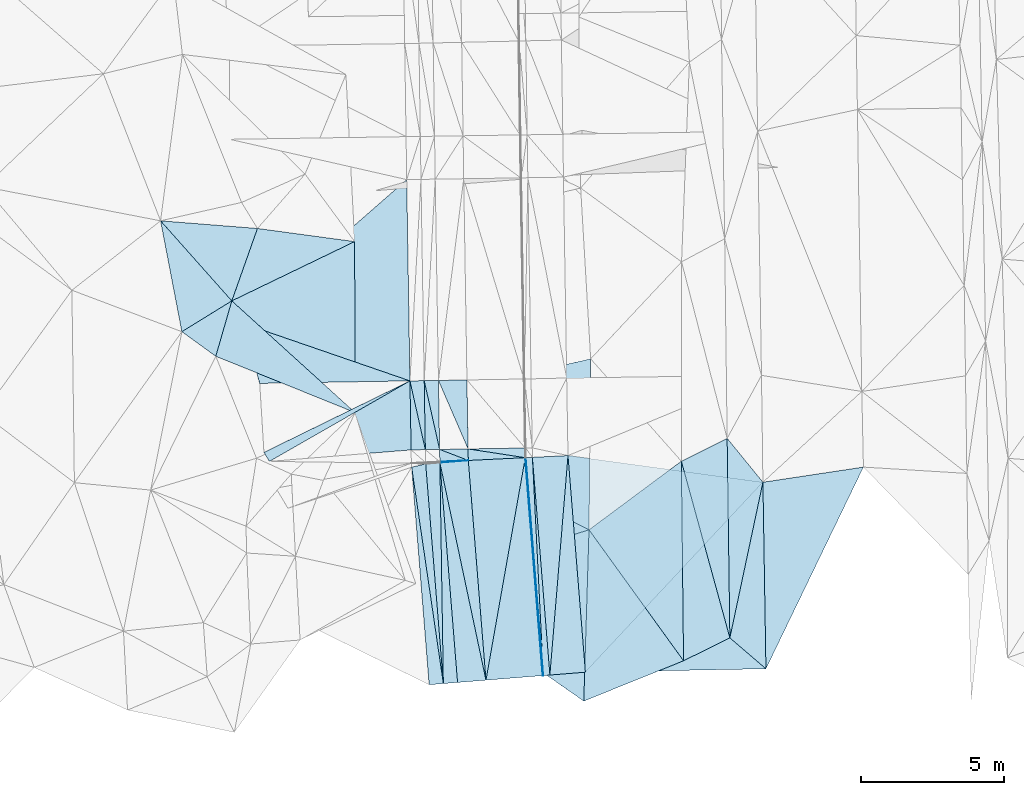
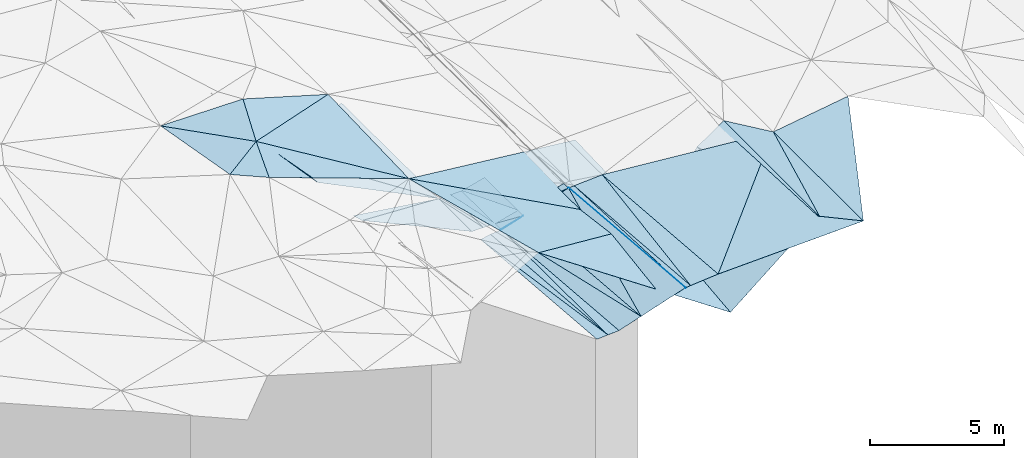
# One storey, part 4 of 275: 46 plates.
"""IFC2X3 building model written with IfcOpenShell, lengths in millimetres."""

from ifc_helpers import new_model, si_unit, frame, origin_with_axes, place, context, subcontext, project, spatial, polyline, outline, extrude, material, type_object, element, save


model = new_model("IFC2X3")

# Units and contexts
model_context = context("Model", 3, precision=1e-05, world=origin_with_axes())
body_context = subcontext(model_context, "Body", "Model", "MODEL_VIEW")
ifc_project = project(units=[si_unit("LENGTHUNIT", "METRE", prefix="MILLI"), si_unit("AREAUNIT", "SQUARE_METRE"), si_unit("VOLUMEUNIT", "CUBIC_METRE"), si_unit("MASSUNIT", "GRAM", prefix="KILO"), si_unit("TIMEUNIT", "SECOND"), si_unit("PLANEANGLEUNIT", "RADIAN"), si_unit("SOLIDANGLEUNIT", "STERADIAN"), si_unit("THERMODYNAMICTEMPERATUREUNIT", "DEGREE_CELSIUS"), si_unit("LUMINOUSINTENSITYUNIT", "LUMEN")], contexts=[model_context])

# Site, building, storey
site_placement = place(None, origin_with_axes())
site = spatial("IfcSite", under=ifc_project, at=site_placement, CompositionType="ELEMENT")
building_placement = place(site_placement, origin_with_axes())
building = spatial("IfcBuilding", under=site, at=building_placement, Name="Undefined", CompositionType="ELEMENT")
storey_placement = place(building_placement, origin_with_axes())
storey = spatial("IfcBuildingStorey", under=building, at=storey_placement, Name="Undefined", CompositionType="ELEMENT", Elevation=0.0)

# Plates
ifc_material = material()
plate_type_1 = type_object("IfcPlateType", PredefinedType="NOTDEFINED")
plate_1_placement = place(storey_placement, frame((-93903.9213803638, -27441.9689943814, 40420.7261829203), z_axis=(0.0194266666543734, 0.019288035695797, -0.999625217920045), x_axis=(0.082182286944694, 0.996399757859899, 0.0208229260497896)))
element("IfcPlate", 1, at=plate_1_placement, inside=storey, type_object=plate_type_1, material=ifc_material, Name="00_PR", context=body_context, shape_type="SweptSolid", body=[
    extrude(outline(polyline([(0.0, 0.0), (7727.4921875, -6.94126356393099e-09), (202.744781494141, 1233.72521972656), (0.0, 0.0)])), frame((-8.85201319254618e-08, 2.18876761149539e-07, -0.5000001331573), z_axis=(0.0, 0.0, 1.0), x_axis=(1.0, 0.0, 0.0)), (0.0, 0.0, 1.0), 1.0),
])
plate_type_2 = type_object("IfcPlateType", PredefinedType="NOTDEFINED")
plate_2_placement = place(storey_placement, frame((-94747.8302942082, -19814.3007240137, 40544.2796965373), z_axis=(0.0483613881429237, 0.0215259640727979, -0.998597921591882), x_axis=(0.0801182170397054, -0.996629915784215, -0.0176034730188981)))
element("IfcPlate", 2, at=plate_2_placement, inside=storey, type_object=plate_type_2, material=ifc_material, Name="00_PR", context=body_context, shape_type="SweptSolid", body=[
    extrude(outline(polyline([(0.0, 0.0), (7671.9521484375, 7.34871719032526e-09), (7671.9697265625, 20.0246315002441), (0.0, 0.0)])), frame((-8.85201319254618e-08, 2.18876761149539e-07, -0.5000001331573), z_axis=(0.0, 0.0, 1.0), x_axis=(1.0, 0.0, 0.0)), (0.0, 0.0, 1.0), 1.0),
])
plate_3_placement = place(storey_placement, frame((-94767.816333404, -19815.2740898309, 40543.288699556), z_axis=(0.0484659400334962, 0.0215340020153302, -0.998592679431345), x_axis=(0.997593448085874, 0.0485850940500555, 0.0494651490676421)))
element("IfcPlate", 3, at=plate_3_placement, inside=storey, type_object=plate_type_2, material=ifc_material, Name="00_PR", context=body_context, shape_type="SweptSolid", body=[
    extrude(outline(polyline([(0.0, 0.0), (20.0343074798584, -1.25510268844664e-10), (235.036758422852, 7668.982421875), (0.0, 0.0)])), frame((-8.85201319254618e-08, 2.18876761149539e-07, -0.5000001331573), z_axis=(0.0, 0.0, 1.0), x_axis=(1.0, 0.0, 0.0)), (0.0, 0.0, 1.0), 1.0),
])
plate_type_3 = type_object("IfcPlateType", PredefinedType="NOTDEFINED")
plate_4_placement = place(storey_placement, frame((-98753.8710590969, -20149.5700390411, 39792.5850713976), z_axis=(-0.00138706794295078, 0.017489506923386, -0.999846084750097), x_axis=(0.972984894181079, 0.230853132107295, 0.00268832507080703)))
element("IfcPlate", 4, at=plate_4_placement, inside=storey, type_object=plate_type_3, material=ifc_material, Name="00_PR", context=body_context, shape_type="SweptSolid", body=[
    extrude(outline(polyline([(0.0, 0.0), (505.891265869141, -1.30967237055302e-10), (-671.246215820313, 7645.65234375), (0.0, 0.0)])), frame((-8.85201319254618e-08, 2.18876761149539e-07, -0.5000001331573), z_axis=(0.0, 0.0, 1.0), x_axis=(1.0, 0.0, 0.0)), (0.0, 0.0, 1.0), 1.0),
])
plate_5_placement = place(storey_placement, frame((-97641.8728961927, -27742.4601534167, 39658.2260711417), z_axis=(-0.00140573286272345, 0.0174867737519264, -0.999846106487827), x_axis=(-0.996784432987784, -0.0801298580631551, -6.42321656705496e-11)))
element("IfcPlate", 5, at=plate_5_placement, inside=storey, type_object=plate_type_3, material=ifc_material, Name="00_PR", context=body_context, shape_type="SweptSolid", body=[
    extrude(outline(polyline([(0.0, 0.0), (499.999908447266, 1.81171344593167e-09), (500.005249023438, 7658.75732421875), (0.0, 0.0)])), frame((-8.85201319254618e-08, 2.18876761149539e-07, -0.5000001331573), z_axis=(0.0, 0.0, 1.0), x_axis=(1.0, 0.0, 0.0)), (0.0, 0.0, 1.0), 1.0),
])
plate_6_placement = place(storey_placement, frame((-98813.807881821, -17121.3449532891, 39843.868083752), z_axis=(-0.000313744370761918, 0.018873461419881, -0.999821831137179), x_axis=(0.999861856982811, 0.016621280061555, 5.8833362722147e-11)))
element("IfcPlate", 6, at=plate_6_placement, inside=storey, type_object=plate_type_3, material=ifc_material, Name="00_PR", context=body_context, shape_type="SweptSolid", body=[
    extrude(outline(polyline([(0.0, 0.0), (500.000274658203, -1.08957465272397e-09), (500.485961914063, 2422.11450195313), (0.0, 0.0)])), frame((-8.85201319254618e-08, 2.18876761149539e-07, -0.5000001331573), z_axis=(0.0, 0.0, 1.0), x_axis=(1.0, 0.0, 0.0)), (0.0, 0.0, 1.0), 1.0),
])
plate_7_placement = place(storey_placement, frame((-98273.139581764, -19534.3746465344, 39798.1480836798), z_axis=(-0.000321296187020533, 0.0188717701491486, -0.999821860663287), x_axis=(-0.999855102254091, -0.0170227640664222, -5.88479248151984e-11)))
element("IfcPlate", 7, at=plate_7_placement, inside=storey, type_object=plate_type_3, material=ifc_material, Name="00_PR", context=body_context, shape_type="SweptSolid", body=[
    extrude(outline(polyline([(0.0, 0.0), (500.000183105469, -1.82262738235295e-09), (499.513519287109, 2422.31518554688), (0.0, 0.0)])), frame((-8.85201319254618e-08, 2.18876761149539e-07, -0.5000001331573), z_axis=(0.0, 0.0, 1.0), x_axis=(1.0, 0.0, 0.0)), (0.0, 0.0, 1.0), 1.0),
])
plate_8_placement = place(storey_placement, frame((-97763.2543987342, -19992.7185375862, 39793.94507152), z_axis=(-0.00140583164995119, 0.017487998141806, -0.999846084934258), x_axis=(0.0156583300668846, -0.999724107342226, -0.0175078810341733)))
element("IfcPlate", 8, at=plate_8_placement, inside=storey, type_object=plate_type_3, material=ifc_material, Name="00_PR", context=body_context, shape_type="SweptSolid", body=[
    extrude(outline(polyline([(0.0, 0.0), (7751.88037109375, 6.53380993753672e-09), (32.2498779296875, 498.958770751953), (0.0, 0.0)])), frame((-8.85201319254618e-08, 2.18876761149539e-07, -0.5000001331573), z_axis=(0.0, 0.0, 1.0), x_axis=(1.0, 0.0, 0.0)), (0.0, 0.0, 1.0), 1.0),
])
plate_9_placement = place(storey_placement, frame((-97641.8728961927, -27742.4601534167, 39658.2260711417), z_axis=(-0.00140583164995119, 0.017487998141806, -0.999846084934258), x_axis=(-0.0156583300654786, 0.999724107342249, 0.0175078810340888)))
element("IfcPlate", 9, at=plate_9_placement, inside=storey, type_object=plate_type_3, material=ifc_material, Name="00_PR", context=body_context, shape_type="SweptSolid", body=[
    extrude(outline(polyline([(0.0, 0.0), (7751.88037109375, 6.53380993753672e-09), (32.2511901855469, 498.959289550781), (0.0, 0.0)])), frame((-8.85201319254618e-08, 2.18876761149539e-07, -0.5000001331573), z_axis=(0.0, 0.0, 1.0), x_axis=(1.0, 0.0, 0.0)), (0.0, 0.0, 1.0), 1.0),
])
plate_10_placement = place(storey_placement, frame((-98313.8766980168, -17113.0343081241, 39843.8680841482), z_axis=(-0.000313755649375687, 0.0188750254590119, -0.999821801608324), x_axis=(0.999861856982811, 0.016621280061555, 5.8833362722147e-11)))
element("IfcPlate", 10, at=plate_10_placement, inside=storey, type_object=plate_type_3, material=ifc_material, Name="00_PR", context=body_context, shape_type="SweptSolid", body=[
    extrude(outline(polyline([(0.0, 0.0), (499.999328613281, 2.29920260608196e-09), (500.48681640625, 2421.91381835938), (0.0, 0.0)])), frame((-8.85201319254618e-08, 2.18876761149539e-07, -0.5000001331573), z_axis=(0.0, 0.0, 1.0), x_axis=(1.0, 0.0, 0.0)), (0.0, 0.0, 1.0), 1.0),
])
plate_11_placement = place(storey_placement, frame((-97773.2127767871, -19525.8636657741, 39798.1480842726), z_axis=(-0.000321308115323835, 0.0188733341866267, -0.999821831136816), x_axis=(-0.999855102254091, -0.0170227640664222, -5.88479248151984e-11)))
element("IfcPlate", 11, at=plate_11_placement, inside=storey, type_object=plate_type_3, material=ifc_material, Name="00_PR", context=body_context, shape_type="SweptSolid", body=[
    extrude(outline(polyline([(0.0, 0.0), (499.999237060547, -2.32103047892451e-09), (499.514434814453, 2422.11450195313), (0.0, 0.0)])), frame((-8.85201319254618e-08, 2.18876761149539e-07, -0.5000001331573), z_axis=(0.0, 0.0, 1.0), x_axis=(1.0, 0.0, 0.0)), (0.0, 0.0, 1.0), 1.0),
])
plate_type_4 = type_object("IfcPlateType", PredefinedType="NOTDEFINED")
plate_12_placement = place(storey_placement, frame((-94517.9869639857, -19803.1105005085, 40555.6756991501), z_axis=(0.0484634257975121, 0.0215340760854367, -0.998592799857437), x_axis=(0.0501828790382111, -0.998557434852281, -0.0190978520433317)))
element("IfcPlate", 12, at=plate_12_placement, inside=storey, type_object=plate_type_4, material=ifc_material, Name="00_PR", context=body_context, shape_type="SweptSolid", body=[
    extrude(outline(polyline([(0.0, 0.0), (7668.34912109375, 1.24709913507104e-08), (-0.142480686306953, 230.397491455078), (0.0, 0.0)])), frame((-8.85201319254618e-08, 2.18876761149539e-07, -0.5000001331573), z_axis=(0.0, 0.0, 1.0), x_axis=(1.0, 0.0, 0.0)), (0.0, 0.0, 1.0), 1.0),
])
plate_13_placement = place(storey_placement, frame((-94133.1671780494, -27460.3975554769, 40409.2266963409), z_axis=(0.0483603371682465, 0.0215289930081994, -0.998597907192393), x_axis=(-0.0501828790382604, 0.998557434852269, 0.0190978520438479)))
element("IfcPlate", 13, at=plate_13_placement, inside=storey, type_object=plate_type_4, material=ifc_material, Name="00_PR", context=body_context, shape_type="SweptSolid", body=[
    extrude(outline(polyline([(0.0, 0.0), (7668.34912109375, 1.24709913507104e-08), (7.1177806854248, 230.177124023438), (0.0, 0.0)])), frame((-8.85201319254618e-08, 2.18876761149539e-07, -0.5000001331573), z_axis=(0.0, 0.0, 1.0), x_axis=(1.0, 0.0, 0.0)), (0.0, 0.0, 1.0), 1.0),
])
plate_type_5 = type_object("IfcPlateType", PredefinedType="NOTDEFINED")
plate_14_placement = place(storey_placement, frame((-94153.0065275495, -27461.9926695257, 40408.2409952261), z_axis=(0.240352015874012, 0.0364545548810631, -0.970001017470457), x_axis=(-0.967022839455476, -0.0777382900809146, -0.242535742163426)))
element("IfcPlate", 14, at=plate_14_placement, inside=storey, type_object=plate_type_5, material=ifc_material, Name="00_PR", context=body_context, shape_type="SweptSolid", body=[
    extrude(outline(polyline([(0.0, 0.0), (2061.552734375, -7.5924617704004e-09), (-32.7596397399902, 7672.51318359375), (0.0, 0.0)])), frame((-8.85201319254618e-08, 2.18876761149539e-07, -0.5000001331573), z_axis=(0.0, 0.0, 1.0), x_axis=(1.0, 0.0, 0.0)), (0.0, 0.0, 1.0), 1.0),
])
plate_type_6 = type_object("IfcPlateType", PredefinedType="NOTDEFINED")
plate_15_placement = place(storey_placement, frame((-96766.3493271711, -19912.582458506, 40043.9599428469), z_axis=(0.241047369469424, 0.0281322543922395, -0.970105531339082), x_axis=(-0.967022839455476, -0.0777382900809146, -0.242535742163426)))
element("IfcPlate", 15, at=plate_15_placement, inside=storey, type_object=plate_type_6, material=ifc_material, Name="00_PR", context=body_context, shape_type="SweptSolid", body=[
    extrude(outline(polyline([(0.0, 0.0), (1030.77587890625, -4.90399543195963e-09), (1030.70703125, 31.573127746582), (0.0, 0.0)])), frame((-8.85201319254618e-08, 2.18876761149539e-07, -0.5000001331573), z_axis=(0.0, 0.0, 1.0), x_axis=(1.0, 0.0, 0.0)), (0.0, 0.0, 1.0), 1.0),
])
plate_type_7 = type_object("IfcPlateType", PredefinedType="NOTDEFINED")
plate_16_placement = place(storey_placement, frame((-104685.761959108, -15098.3733626785, 42798.3208181357), z_axis=(-0.447294633196826, 0.00785011717617007, -0.894352216284858), x_axis=(0.705648401141284, 0.617499565206681, -0.347497656015562)))
element("IfcPlate", 16, at=plate_16_placement, inside=storey, type_object=plate_type_7, material=ifc_material, Name="00_PR", context=body_context, shape_type="SweptSolid", body=[
    extrude(outline(polyline([(0.0, 0.0), (8160.54736328125, 3.30328475683928e-08), (3920.8369140625, 5650.23681640625), (0.0, 0.0)])), frame((-8.85201319254618e-08, 2.18876761149539e-07, -0.5000001331573), z_axis=(0.0, 0.0, 1.0), x_axis=(1.0, 0.0, 0.0)), (0.0, 0.0, 1.0), 1.0),
])
plate_type_8 = type_object("IfcPlateType", PredefinedType="NOTDEFINED")
plate_17_placement = place(storey_placement, frame((-98814.0314003795, -17121.3505676178, 39843.9208318373), z_axis=(-0.447351614592803, 0.00764569168444113, -0.894325486788718), x_axis=(-0.894303528603165, -0.0148773440733427, 0.447213442733168)))
element("IfcPlate", 17, at=plate_17_placement, inside=storey, type_object=plate_type_8, material=ifc_material, Name="00_PR", context=body_context, shape_type="SweptSolid", body=[
    extrude(outline(polyline([(0.0, 0.0), (5893.58642578125, 2.90328898699954e-08), (6542.26025390625, 2120.60522460938), (0.0, 0.0)])), frame((-8.85201319254618e-08, 2.18876761149539e-07, -0.5000001331573), z_axis=(0.0, 0.0, 1.0), x_axis=(1.0, 0.0, 0.0)), (0.0, 0.0, 1.0), 1.0),
])
plate_type_9 = type_object("IfcPlateType", PredefinedType="NOTDEFINED")
plate_18_placement = place(storey_placement, frame((-98814.029891733, -17121.3535997739, 39843.9200650892), z_axis=(-0.444335584173495, 0.00158157374754733, -0.895859021979284), x_axis=(-0.797225700057682, -0.456854085105193, 0.394608068962402)))
element("IfcPlate", 18, at=plate_18_placement, inside=storey, type_object=plate_type_9, material=ifc_material, Name="00_PR", context=body_context, shape_type="SweptSolid", body=[
    extrude(outline(polyline([(0.0, 0.0), (6184.82275390625, -4.41214069724083e-08), (6230.7529296875, 379.465423583984), (0.0, 0.0)])), frame((-8.85201319254618e-08, 2.18876761149539e-07, -0.5000001331573), z_axis=(0.0, 0.0, 1.0), x_axis=(1.0, 0.0, 0.0)), (0.0, 0.0, 1.0), 1.0),
])
plate_19_placement = place(storey_placement, frame((-97773.0914548672, -19525.8659862459, 39798.1629488576), z_axis=(0.242316001610716, 0.0142322263630527, -0.970092984768031), x_axis=(0.970001948420717, 0.0165145060502906, 0.242535546157521)))
element("IfcPlate", 19, at=plate_19_placement, inside=storey, type_object=plate_type_9, material=ifc_material, Name="00_PR", context=body_context, shape_type="SweptSolid", body=[
    extrude(outline(polyline([(0.0, 0.0), (1030.77673339844, -2.18278728425503e-09), (1029.77038574219, 403.825561523438), (0.0, 0.0)])), frame((-8.85201319254618e-08, 2.18876761149539e-07, -0.5000001331573), z_axis=(0.0, 0.0, 1.0), x_axis=(1.0, 0.0, 0.0)), (0.0, 0.0, 1.0), 1.0),
])
plate_type_10 = type_object("IfcPlateType", PredefinedType="NOTDEFINED")
plate_20_placement = place(storey_placement, frame((-103744.731391015, -19946.9113021958, 42284.5019728692), z_axis=(-0.447885042391753, 0.0093446771138816, -0.894042317684893), x_axis=(0.797225700057736, 0.456854085104726, -0.394608068962834)))
element("IfcPlate", 20, at=plate_20_placement, inside=storey, type_object=plate_type_10, material=ifc_material, Name="00_PR", context=body_context, shape_type="SweptSolid", body=[
    extrude(outline(polyline([(0.0, 0.0), (6184.82275390625, -4.41214069724083e-08), (5129.052734375, 2180.12866210938), (0.0, 0.0)])), frame((-8.85201319254618e-08, 2.18876761149539e-07, -0.5000001331573), z_axis=(0.0, 0.0, 1.0), x_axis=(1.0, 0.0, 0.0)), (0.0, 0.0, 1.0), 1.0),
])
plate_type_11 = type_object("IfcPlateType", PredefinedType="NOTDEFINED")
plate_21_placement = place(storey_placement, frame((-94767.7194486122, -19815.2758670566, 40543.302970806), z_axis=(0.242241395631777, 0.0179772710575199, -0.970049444084008), x_axis=(-0.960340231072476, 0.146735958965719, -0.237097446064007)))
element("IfcPlate", 21, at=plate_21_placement, inside=storey, type_object=plate_type_11, material=ifc_material, Name="00_PR", context=body_context, shape_type="SweptSolid", body=[
    extrude(outline(polyline([(0.0, 0.0), (2088.33959960938, -3.00133251585066e-09), (54.3843421936035, 336.19482421875), (0.0, 0.0)])), frame((-8.85201319254618e-08, 2.18876761149539e-07, -0.5000001331573), z_axis=(0.0, 0.0, 1.0), x_axis=(1.0, 0.0, 0.0)), (0.0, 0.0, 1.0), 1.0),
])
plate_type_12 = type_object("IfcPlateType", PredefinedType="NOTDEFINED")
plate_22_placement = place(storey_placement, frame((-96766.3489919128, -19912.5894129051, 40043.9598740667), z_axis=(0.241715600192667, 0.0142235450640752, -0.970242886801706), x_axis=(-0.017055120057383, 0.99980037904314, 0.0104079270281062)))
element("IfcPlate", 22, at=plate_22_placement, inside=storey, type_object=plate_type_12, material=ifc_material, Name="00_PR", context=body_context, shape_type="SweptSolid", body=[
    extrude(outline(polyline([(0.0, 0.0), (403.826812744141, -4.80213202536106e-10), (68.4025039672852, 2061.22607421875), (0.0, 0.0)])), frame((-8.85201319254618e-08, 2.18876761149539e-07, -0.5000001331573), z_axis=(0.0, 0.0, 1.0), x_axis=(1.0, 0.0, 0.0)), (0.0, 0.0, 1.0), 1.0),
])
plate_type_13 = type_object("IfcPlateType", PredefinedType="NOTDEFINED")
plate_23_placement = place(storey_placement, frame((-97813.825186393, -17104.7223095351, 39843.8830058854), z_axis=(0.242155836405969, 0.0223938511382291, -0.969978899938408), x_axis=(0.970008511473331, 0.0161250090542031, 0.242535506168262)))
element("IfcPlate", 23, at=plate_23_placement, inside=storey, type_object=plate_type_13, material=ifc_material, Name="00_PR", context=body_context, shape_type="SweptSolid", body=[
    extrude(outline(polyline([(0.0, 0.0), (1030.77685546875, 5.06406649947166e-09), (1020.15905761719, 2421.48901367188), (0.0, 0.0)])), frame((-8.85201319254618e-08, 2.18876761149539e-07, -0.5000001331573), z_axis=(0.0, 0.0, 1.0), x_axis=(1.0, 0.0, 0.0)), (0.0, 0.0, 1.0), 1.0),
])
plate_type_14 = type_object("IfcPlateType", PredefinedType="NOTDEFINED")
plate_24_placement = place(storey_placement, frame((-96766.3489370481, -19912.5900949744, 40043.9598778745), z_axis=(0.241823419271486, 0.0128596062880025, -0.970235056271399), x_axis=(-0.969087411984123, -0.0471885210401059, -0.242162820052878)))
element("IfcPlate", 24, at=plate_24_placement, inside=storey, type_object=plate_type_14, material=ifc_material, Name="00_PR", context=body_context, shape_type="SweptSolid", body=[
    extrude(outline(polyline([(0.0, 0.0), (1031.19055175781, -1.77897163666785e-09), (1016.89575195313, 435.230102539063), (0.0, 0.0)])), frame((-8.85201319254618e-08, 2.18876761149539e-07, -0.5000001331573), z_axis=(0.0, 0.0, 1.0), x_axis=(1.0, 0.0, 0.0)), (0.0, 0.0, 1.0), 1.0),
])
plate_type_15 = type_object("IfcPlateType", PredefinedType="NOTDEFINED")
plate_25_placement = place(storey_placement, frame((-97763.1335158941, -19992.7090829398, 39793.9599946256), z_axis=(0.240356929735878, 0.0363977409809368, -0.97000193338953), x_axis=(0.967022839453793, 0.0777382900775972, 0.242535742171202)))
element("IfcPlate", 25, at=plate_25_placement, inside=storey, type_object=plate_type_15, material=ifc_material, Name="00_PR", context=body_context, shape_type="SweptSolid", body=[
    extrude(outline(polyline([(0.0, 0.0), (1030.77587890625, -4.90399543195963e-09), (997.858276367188, 7735.66845703125), (0.0, 0.0)])), frame((-8.85201319254618e-08, 2.18876761149539e-07, -0.5000001331573), z_axis=(0.0, 0.0, 1.0), x_axis=(1.0, 0.0, 0.0)), (0.0, 0.0, 1.0), 1.0),
])
plate_26_placement = place(storey_placement, frame((-96146.5751303928, -27622.2546160126, 39908.2409942586), z_axis=(0.240356929735878, 0.0363977409809368, -0.97000193338953), x_axis=(-0.967022931495099, -0.0777373790798052, -0.242535667184083)))
element("IfcPlate", 26, at=plate_26_placement, inside=storey, type_object=plate_type_15, material=ifc_material, Name="00_PR", context=body_context, shape_type="SweptSolid", body=[
    extrude(outline(polyline([(0.0, 0.0), (1030.77624511719, -1.9317667465657e-09), (997.865356445313, 7735.66748046875), (0.0, 0.0)])), frame((-8.85201319254618e-08, 2.18876761149539e-07, -0.5000001331573), z_axis=(0.0, 0.0, 1.0), x_axis=(1.0, 0.0, 0.0)), (0.0, 0.0, 1.0), 1.0),
])
plate_type_16 = type_object("IfcPlateType", PredefinedType="NOTDEFINED")
plate_27_placement = place(storey_placement, frame((-96146.5750263022, -27622.2546086271, 39908.2410199958), z_axis=(0.240562140875055, 0.0364133313230105, -0.969950475890172), x_axis=(-0.0801183430531477, 0.996630947062237, 0.0175444140468081)))
element("IfcPlate", 27, at=plate_27_placement, inside=storey, type_object=plate_type_16, material=ifc_material, Name="00_PR", context=body_context, shape_type="SweptSolid", body=[
    extrude(outline(polyline([(0.0, 0.0), (7735.73828125, 1.3882527127862e-08), (7681.35595703125, 2061.6435546875), (0.0, 0.0)])), frame((-8.85201319254618e-08, 2.18876761149539e-07, -0.5000001331573), z_axis=(0.0, 0.0, 1.0), x_axis=(1.0, 0.0, 0.0)), (0.0, 0.0, 1.0), 1.0),
])
plate_type_17 = type_object("IfcPlateType", PredefinedType="NOTDEFINED")
plate_28_placement = place(storey_placement, frame((-86429.8554762613, -20677.0234128744, 40706.6621994828), z_axis=(0.0205604092467718, 0.0197502975849723, -0.999593515043445), x_axis=(0.0161789230449029, -0.999680516825508, -0.0194192360455478)))
element("IfcPlate", 28, at=plate_28_placement, inside=storey, type_object=plate_type_17, material=ifc_material, Name="00_PR", context=body_context, shape_type="SweptSolid", body=[
    extrude(outline(polyline([(0.0, 0.0), (6548.24951171875, 7.56699591875076e-10), (6566.93408203125, 6336.5), (0.0, 0.0)])), frame((-8.85201319254618e-08, 2.18876761149539e-07, -0.5000001331573), z_axis=(0.0, 0.0, 1.0), x_axis=(1.0, 0.0, 0.0)), (0.0, 0.0, 1.0), 1.0),
])
plate_type_18 = type_object("IfcPlateType", PredefinedType="NOTDEFINED")
plate_29_placement = place(storey_placement, frame((-93268.8581899215, -19742.2975448387, 40581.6351869243), z_axis=(0.0198369281045527, 0.0192540429580893, -0.999617816024276), x_axis=(-0.0821822869449237, -0.996399757859927, -0.020822926047522)))
element("IfcPlate", 29, at=plate_29_placement, inside=storey, type_object=plate_type_18, material=ifc_material, Name="00_PR", context=body_context, shape_type="SweptSolid", body=[
    extrude(outline(polyline([(0.0, 0.0), (7727.4921875, -6.94126356393099e-09), (163.793151855469, 1240.12194824219), (0.0, 0.0)])), frame((-8.85201319254618e-08, 2.18876761149539e-07, -0.5000001331573), z_axis=(0.0, 0.0, 1.0), x_axis=(1.0, 0.0, 0.0)), (0.0, 0.0, 1.0), 1.0),
])
plate_type_19 = type_object("IfcPlateType", PredefinedType="NOTDEFINED")
plate_30_placement = place(storey_placement, frame((-92657.9402659332, -27341.8055151517, 40446.8731992767), z_axis=(0.0209266288544826, 0.0194080384983401, -0.999592619143636), x_axis=(-0.0801180530307317, 0.996628694816362, 0.0176732070434485)))
element("IfcPlate", 30, at=plate_30_placement, inside=storey, type_object=plate_type_19, material=ifc_material, Name="00_PR", context=body_context, shape_type="SweptSolid", body=[
    extrude(outline(polyline([(0.0, 0.0), (7625.21484375, -1.57160684466362e-09), (6147.92236328125, 6743.8046875), (0.0, 0.0)])), frame((-8.85201319254618e-08, 2.18876761149539e-07, -0.5000001331573), z_axis=(0.0, 0.0, 1.0), x_axis=(1.0, 0.0, 0.0)), (0.0, 0.0, 1.0), 1.0),
])
plate_type_20 = type_object("IfcPlateType", PredefinedType="NOTDEFINED")
plate_31_placement = place(storey_placement, frame((-105063.805961171, -14314.2159210541, 42939.5008858978), z_axis=(0.0595533790741394, 0.0103456636726387, -0.998171509453172), x_axis=(-0.664351511079503, 0.746739338179924, -0.0318971870388275)))
element("IfcPlate", 31, at=plate_31_placement, inside=storey, type_object=plate_type_20, material=ifc_material, Name="00", context=body_context, shape_type="SweptSolid", body=[
    extrude(outline(polyline([(0.0, 0.0), (3762.08715820313, 4.24915924668312e-09), (1297.07250976563, 2363.91674804688), (0.0, 0.0)])), frame((-8.85201319254618e-08, 2.18876761149539e-07, -0.5000001331573), z_axis=(0.0, 0.0, 1.0), x_axis=(1.0, 0.0, 0.0)), (0.0, 0.0, 1.0), 1.0),
])
plate_type_21 = type_object("IfcPlateType", PredefinedType="NOTDEFINED")
plate_32_placement = place(storey_placement, frame((-89291.5570337859, -19939.1344349208, 40580.5017354612), z_axis=(0.0805094732676608, 0.0225968971184386, -0.996497669317286), x_axis=(0.891424389822983, 0.44566558253042, 0.0821264012150997)))
element("IfcPlate", 32, at=plate_32_placement, inside=storey, type_object=plate_type_21, material=ifc_material, Name="00", context=body_context, shape_type="SweptSolid", body=[
    extrude(outline(polyline([(0.0, 0.0), (1802.10021972656, -1.51703716255724e-09), (-1244.82263183594, 6305.74951171875), (0.0, 0.0)])), frame((-8.85201319254618e-08, 2.18876761149539e-07, -0.5000001331573), z_axis=(0.0, 0.0, 1.0), x_axis=(1.0, 0.0, 0.0)), (0.0, 0.0, 1.0), 1.0),
])
plate_type_22 = type_object("IfcPlateType", PredefinedType="NOTDEFINED")
plate_33_placement = place(storey_placement, frame((-86323.9127362402, -27223.1805187239, 40579.5001699386), z_axis=(0.018884465526904, 0.0201570298262558, -0.999618462769844), x_axis=(-0.75875609747941, 0.651373737553759, -0.00119940112645089)))
element("IfcPlate", 33, at=plate_33_placement, inside=storey, type_object=plate_type_22, material=ifc_material, Name="00", context=body_context, shape_type="SweptSolid", body=[
    extrude(outline(polyline([(0.0, 0.0), (1667.4990234375, 9.74978320300579e-10), (4344.224609375, 4899.79736328125), (0.0, 0.0)])), frame((-8.85201319254618e-08, 2.18876761149539e-07, -0.5000001331573), z_axis=(0.0, 0.0, 1.0), x_axis=(1.0, 0.0, 0.0)), (0.0, 0.0, 1.0), 1.0),
])
plate_type_23 = type_object("IfcPlateType", PredefinedType="NOTDEFINED")
plate_34_placement = place(storey_placement, frame((-87589.1414735453, -26137.0146552515, 40577.5001377505), z_axis=(0.0115324597242765, 0.0217199414082226, -0.99969757752929), x_axis=(-0.0137098235141392, 0.999673523045556, 0.0215612629708164)))
element("IfcPlate", 34, at=plate_34_placement, inside=storey, type_object=plate_type_23, material=ifc_material, Name="00", context=body_context, shape_type="SweptSolid", body=[
    extrude(outline(polyline([(0.0, 0.0), (7003.30029296875, 1.12340785562992e-08), (5445.162109375, 1234.13171386719), (0.0, 0.0)])), frame((-8.85201319254618e-08, 2.18876761149539e-07, -0.5000001331573), z_axis=(0.0, 0.0, 1.0), x_axis=(1.0, 0.0, 0.0)), (0.0, 0.0, 1.0), 1.0),
])
plate_type_24 = type_object("IfcPlateType", PredefinedType="NOTDEFINED")
plate_35_placement = place(storey_placement, frame((-104164.419956497, -11773.5067342733, 43019.5113086784), z_axis=(-0.188035492696106, 0.0973468703977708, -0.977326066525544), x_axis=(0.971014360891906, -0.131073940364321, -0.199876794798831)))
element("IfcPlate", 35, at=plate_35_placement, inside=storey, type_object=plate_type_24, material=ifc_material, Name="00", context=body_context, shape_type="SweptSolid", body=[
    extrude(outline(polyline([(0.0, 0.0), (3512.16357421875, 1.68765836860985e-08), (-524.431701660156, 2644.89526367188), (0.0, 0.0)])), frame((-8.85201319254618e-08, 2.18876761149539e-07, -0.5000001331573), z_axis=(0.0, 0.0, 1.0), x_axis=(1.0, 0.0, 0.0)), (0.0, 0.0, 1.0), 1.0),
])
plate_type_25 = type_object("IfcPlateType", PredefinedType="NOTDEFINED")
plate_36_placement = place(storey_placement, frame((-107563.131685327, -11504.8972284323, 42819.503367944), z_axis=(0.104716535930328, 0.0507380262487536, -0.993206977318994), x_axis=(0.66435151108093, -0.746739338178, 0.0318971870541409)))
element("IfcPlate", 36, at=plate_36_placement, inside=storey, type_object=plate_type_25, material=ifc_material, Name="00", context=body_context, shape_type="SweptSolid", body=[
    extrude(outline(polyline([(0.0, 0.0), (3762.08715820313, 4.24915924668312e-09), (3397.28979492188, 2040.71618652344), (0.0, 0.0)])), frame((-8.85201319254618e-08, 2.18876761149539e-07, -0.5000001331573), z_axis=(0.0, 0.0, 1.0), x_axis=(1.0, 0.0, 0.0)), (0.0, 0.0, 1.0), 1.0),
])
plate_type_26 = type_object("IfcPlateType", PredefinedType="NOTDEFINED")
plate_37_placement = place(storey_placement, frame((-105063.915322856, -14314.2037113073, 42939.5066524236), z_axis=(-0.159171624222164, 0.0347639726938977, -0.986638667519683), x_axis=(0.893065917004992, 0.431070029673689, -0.128887149868237)))
element("IfcPlate", 37, at=plate_37_placement, inside=storey, type_object=plate_type_26, material=ifc_material, Name="00", context=body_context, shape_type="SweptSolid", body=[
    extrude(outline(polyline([(0.0, 0.0), (4825.92724609375, -3.71073838323355e-10), (2280.78149414063, 5438.8232421875), (0.0, 0.0)])), frame((-8.85201319254618e-08, 2.18876761149539e-07, -0.5000001331573), z_axis=(0.0, 0.0, 1.0), x_axis=(1.0, 0.0, 0.0)), (0.0, 0.0, 1.0), 1.0),
])
plate_type_27 = type_object("IfcPlateType", PredefinedType="NOTDEFINED")
plate_38_placement = place(storey_placement, frame((-105626.061566589, -16257.4489713632, 42669.5045349393), z_axis=(0.0618082390176265, 0.119788622007604, -0.990873567932387), x_axis=(-0.809651685327678, 0.586555838478932, 0.0204058029081751)))
element("IfcPlate", 38, at=plate_38_placement, inside=storey, type_object=plate_type_27, material=ifc_material, Name="00", context=body_context, shape_type="SweptSolid", body=[
    extrude(outline(polyline([(0.0, 0.0), (1470.17004394531, 5.0058588385582e-09), (690.124267578125, 1920.71044921875), (0.0, 0.0)])), frame((-8.85201319254618e-08, 2.18876761149539e-07, -0.5000001331573), z_axis=(0.0, 0.0, 1.0), x_axis=(1.0, 0.0, 0.0)), (0.0, 0.0, 1.0), 1.0),
])
plate_type_28 = type_object("IfcPlateType", PredefinedType="NOTDEFINED")
plate_39_placement = place(storey_placement, frame((-100738.155399669, -18234.8754461266, 42103.5065108344), z_axis=(-0.0526447485998576, 0.152354695405707, -0.9869227817984), x_axis=(-0.92171890628285, 0.372884620444515, 0.106730115884396)))
element("IfcPlate", 39, at=plate_39_placement, inside=storey, type_object=plate_type_28, material=ifc_material, Name="00", context=body_context, shape_type="SweptSolid", body=[
    extrude(outline(polyline([(0.0, 0.0), (5303.095703125, -1.78260961547494e-09), (5538.2919921875, 2027.33386230469), (0.0, 0.0)])), frame((-8.85201319254618e-08, 2.18876761149539e-07, -0.5000001331573), z_axis=(0.0, 0.0, 1.0), x_axis=(1.0, 0.0, 0.0)), (0.0, 0.0, 1.0), 1.0),
])
plate_type_29 = type_object("IfcPlateType", PredefinedType="NOTDEFINED")
plate_40_placement = place(storey_placement, frame((-87589.099117903, -26137.0120597649, 40577.502488206), z_axis=(0.0962488245837943, 0.026919495587832, -0.994993218330424), x_axis=(-0.89179463957239, -0.441651606408696, -0.0982149651864222)))
element("IfcPlate", 40, at=plate_40_placement, inside=storey, type_object=plate_type_29, material=ifc_material, Name="00", context=body_context, shape_type="SweptSolid", body=[
    extrude(outline(polyline([(0.0, 0.0), (1822.53283691406, 9.88802639767528e-09), (-1219.36242675781, 6310.72216796875), (0.0, 0.0)])), frame((-8.85201319254618e-08, 2.18876761149539e-07, -0.5000001331573), z_axis=(0.0, 0.0, 1.0), x_axis=(1.0, 0.0, 0.0)), (0.0, 0.0, 1.0), 1.0),
])
plate_type_30 = type_object("IfcPlateType", PredefinedType="NOTDEFINED")
plate_41_placement = place(storey_placement, frame((-86429.85740026, -20677.0231929145, 40709.5001514119), z_axis=(0.0168122885955703, 0.0201242410453829, -0.999656121811159), x_axis=(0.988652679114721, 0.148931942675349, 0.0196254052246202)))
element("IfcPlate", 41, at=plate_41_placement, inside=storey, type_object=plate_type_30, material=ifc_material, Name="00", context=body_context, shape_type="SweptSolid", body=[
    extrude(outline(polyline([(0.0, 0.0), (3566.80517578125, -1.56032911036164e-08), (-872.741760253906, 6489.88623046875), (0.0, 0.0)])), frame((-8.85201319254618e-08, 2.18876761149539e-07, -0.5000001331573), z_axis=(0.0, 0.0, 1.0), x_axis=(1.0, 0.0, 0.0)), (0.0, 0.0, 1.0), 1.0),
])
plate_type_31 = type_object("IfcPlateType", PredefinedType="NOTDEFINED")
plate_42_placement = place(storey_placement, frame((-89214.3370976794, -26941.9243725278, 40398.519290331), z_axis=(0.270336577311209, 0.0514247334507564, -0.961391508053394), x_axis=(-0.892494478479389, -0.361113278431552, -0.270279126134855)))
element("IfcPlate", 42, at=plate_42_placement, inside=storey, type_object=plate_type_31, material=ifc_material, Name="00", context=body_context, shape_type="SweptSolid", body=[
    extrude(outline(polyline([(0.0, 0.0), (3921.87158203125, -1.98087946046144e-09), (1486.97473144531, 5511.7861328125), (0.0, 0.0)])), frame((-8.85201319254618e-08, 2.18876761149539e-07, -0.5000001331573), z_axis=(0.0, 0.0, 1.0), x_axis=(1.0, 0.0, 0.0)), (0.0, 0.0, 1.0), 1.0),
])
plate_type_32 = type_object("IfcPlateType", PredefinedType="NOTDEFINED")
plate_43_placement = place(storey_placement, frame((-89214.3524770585, -26941.9361545557, 40398.5147473019), z_axis=(0.239577556304734, 0.0278608824832976, -0.970477390639423), x_axis=(-0.581073834646972, 0.804904696926882, -0.120339634176393)))
element("IfcPlate", 43, at=plate_43_placement, inside=storey, type_object=plate_type_32, material=ifc_material, Name="00", context=body_context, shape_type="SweptSolid", body=[
    extrude(outline(polyline([(0.0, 0.0), (5708.84228515625, -2.37923813983798e-08), (5659.50341796875, 4128.9658203125), (0.0, 0.0)])), frame((-8.85201319254618e-08, 2.18876761149539e-07, -0.5000001331573), z_axis=(0.0, 0.0, 1.0), x_axis=(1.0, 0.0, 0.0)), (0.0, 0.0, 1.0), 1.0),
])
plate_type_33 = type_object("IfcPlateType", PredefinedType="NOTDEFINED")
plate_44_placement = place(storey_placement, frame((-98607.8755054728, -24235.9965842802, 41619.5219544282), z_axis=(-0.291971436877298, -0.0265426766494617, -0.95605866261652), x_axis=(-0.333587342480892, 0.939667940535438, 0.0757868489015411)))
element("IfcPlate", 44, at=plate_44_placement, inside=storey, type_object=plate_type_33, material=ifc_material, Name="00", context=body_context, shape_type="SweptSolid", body=[
    extrude(outline(polyline([(0.0, 0.0), (6386.33251953125, -1.34896254166961e-08), (-396.343933105469, 6630.97705078125), (0.0, 0.0)])), frame((-8.85201319254618e-08, 2.18876761149539e-07, -0.5000001331573), z_axis=(0.0, 0.0, 1.0), x_axis=(1.0, 0.0, 0.0)), (0.0, 0.0, 1.0), 1.0),
])
plate_type_34 = type_object("IfcPlateType", PredefinedType="NOTDEFINED")
plate_45_placement = place(storey_placement, frame((-92473.483846312, -16347.9982728956, 39833.5186119817), z_axis=(-0.269496188104552, 0.0222023099724251, -0.962745481437854), x_axis=(-0.00972971239829218, -0.999745938800254, -0.0203320079934196)))
element("IfcPlate", 45, at=plate_45_placement, inside=storey, type_object=plate_type_34, material=ifc_material, Name="00", context=body_context, shape_type="SweptSolid", body=[
    extrude(outline(polyline([(0.0, 0.0), (6000.39111328125, -4.30736690759659e-09), (1920.72314453125, 8563.34375), (0.0, 0.0)])), frame((-8.85201319254618e-08, 2.18876761149539e-07, -0.5000001331573), z_axis=(0.0, 0.0, 1.0), x_axis=(1.0, 0.0, 0.0)), (0.0, 0.0, 1.0), 1.0),
])
plate_type_35 = type_object("IfcPlateType", PredefinedType="NOTDEFINED")
plate_46_placement = place(storey_placement, frame((-92531.8902665314, -22346.8418862517, 39711.5272024106), z_axis=(-0.318181057917291, 0.0683575358176604, -0.945562299205912), x_axis=(-0.0303684423957279, -0.997620118629959, -0.0619019919809077)))
element("IfcPlate", 46, at=plate_46_placement, inside=storey, type_object=plate_type_35, material=ifc_material, Name="00", context=body_context, shape_type="SweptSolid", body=[
    extrude(outline(polyline([(0.0, 0.0), (6025.654296875, -6.53380993753672e-09), (1951.02099609375, 6349.83984375), (0.0, 0.0)])), frame((-8.85201319254618e-08, 2.18876761149539e-07, -0.5000001331573), z_axis=(0.0, 0.0, 1.0), x_axis=(1.0, 0.0, 0.0)), (0.0, 0.0, 1.0), 1.0),
])

save(model, "model.ifc")
